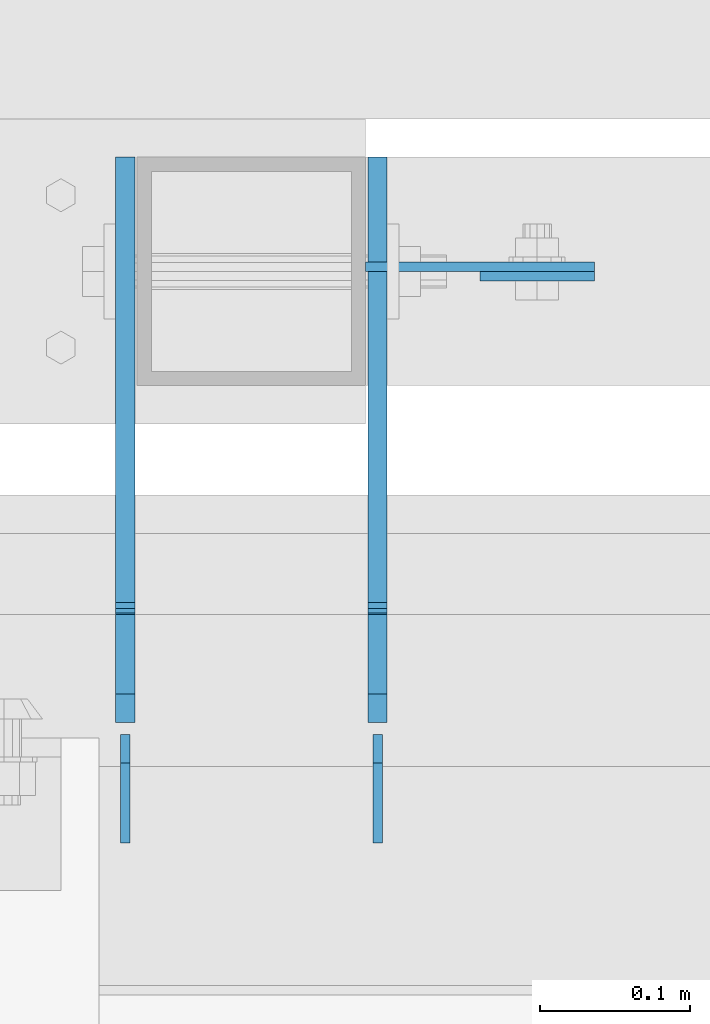
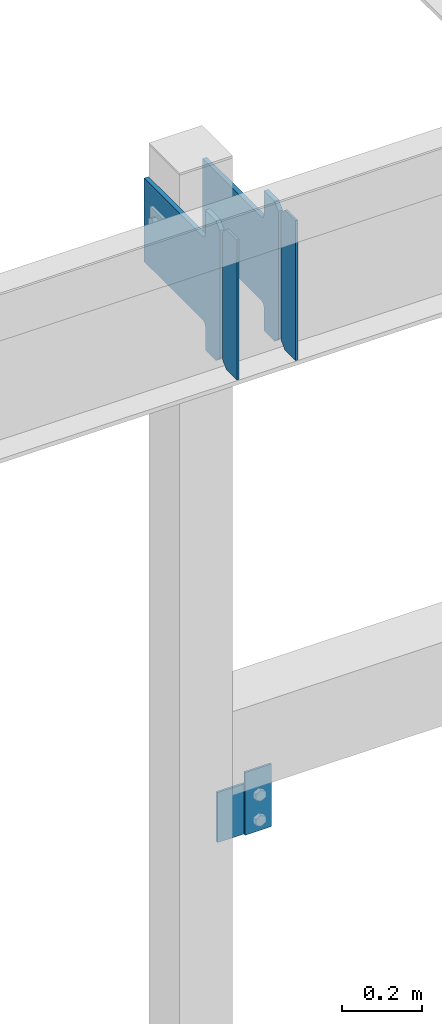
# One storey, part 3497 of 3843: 6 plates, 3 elements without a shape of their own.
"""IFC2X3 building model written with IfcOpenShell, lengths in millimetres."""

from ifc_helpers import new_model, si_unit, frame, origin_with_axes, place, context, subcontext, project, spatial, faceted_brep, material, type_object, element, aggregate, save


model = new_model("IFC2X3")

# Units and contexts
model_context = context("Model", 3, precision=1e-05, world=origin_with_axes())
body_context = subcontext(model_context, "Body", "Model", "MODEL_VIEW")
ifc_project = project(units=[si_unit("LENGTHUNIT", "METRE", prefix="MILLI"), si_unit("AREAUNIT", "SQUARE_METRE"), si_unit("VOLUMEUNIT", "CUBIC_METRE"), si_unit("MASSUNIT", "GRAM", prefix="KILO"), si_unit("TIMEUNIT", "SECOND"), si_unit("PLANEANGLEUNIT", "RADIAN"), si_unit("SOLIDANGLEUNIT", "STERADIAN"), si_unit("THERMODYNAMICTEMPERATUREUNIT", "DEGREE_CELSIUS"), si_unit("LUMINOUSINTENSITYUNIT", "LUMEN")], contexts=[model_context])

# Site, building, storey
site_placement = place(None, origin_with_axes())
site = spatial("IfcSite", under=ifc_project, at=site_placement, CompositionType="ELEMENT")
building_placement = place(site_placement, origin_with_axes())
building = spatial("IfcBuilding", under=site, at=building_placement, Name="Undefined", CompositionType="ELEMENT")
storey_placement = place(building_placement, origin_with_axes())
storey = spatial("IfcBuildingStorey", under=building, at=storey_placement, Name="Undefined", CompositionType="ELEMENT", Elevation=0.0)

# Assembly, plate
assembly_1_placement = place(storey_placement, origin_with_axes())
assembly_1 = element("IfcElementAssembly", 1, at=assembly_1_placement, inside=storey, Name="POST", AssemblyPlace="NOTDEFINED", PredefinedType="RIGID_FRAME")
ifc_material = material(Name="STEEL/A572-50")
plate_type_1 = type_object("IfcPlateType", PredefinedType="NOTDEFINED")
plate_1_placement = place(assembly_1_placement, frame((64033.4, 92522.675, 34455.1), z_axis=(0.0, 0.0, -1.0), x_axis=(1.0, 0.0, 0.0)))
plate_1 = element("IfcPlate", 2, at=plate_1_placement, type_object=plate_type_1, material=ifc_material, Name="PLATE", context=body_context, shape_type="Brep", body=[
    faceted_brep([(0.0, -3.17499999999927, 0.0), (1.52795109897852e-10, -3.17500000000291, 152.400000000009), (1.52795109897852e-10, 3.17500000000291, 152.400000000009), (0.0, 3.17499999999927, 0.0), (152.399993896484, -3.17500000000291, 152.399993896484), (152.399993896484, 3.17500000000291, 152.399993896484), (152.399998474109, -3.17500000000291, 0.0), (152.399998474109, 3.17500000000291, 0.0)], [[[0, 1, 2, 3]], [[1, 4, 5, 2]], [[4, 6, 7, 5]], [[6, 0, 3, 7]], [[5, 7, 3, 2]], [[6, 4, 1, 0]]]),
])
aggregate(assembly_1, [plate_1])

assembly_2_placement = place(storey_placement, origin_with_axes())
assembly_2 = element("IfcElementAssembly", 3, at=assembly_2_placement, inside=storey, Name="BEAM", AssemblyPlace="NOTDEFINED", PredefinedType="RIGID_FRAME")
plate_type_2 = type_object("IfcPlateType", PredefinedType="NOTDEFINED")
plate_2_placement = place(assembly_2_placement, frame((64185.7999938965, 92516.325, 34302.7000061036), z_axis=(-1.0, 0.0, 0.0), x_axis=(0.0, 0.0, 1.0)))
plate_2 = element("IfcPlate", 4, at=plate_2_placement, type_object=plate_type_2, material=ifc_material, Name="PLATE", context=body_context, shape_type="Brep", body=[
    faceted_brep([(0.0, -3.17499999999927, 0.0), (0.0, -3.17499999999927, 76.1999969482422), (0.0, 3.17499999999927, 76.1999969482422), (0.0, 3.17499999999927, 0.0), (190.5, -3.17500000000291, 76.1999969482422), (190.5, 3.17500000000291, 76.1999969482422), (190.5, -3.17500000000291, -3.63797880709171e-12), (190.5, 3.17500000000291, -3.63797880709171e-12)], [[[0, 1, 2, 3]], [[1, 4, 5, 2]], [[4, 6, 7, 5]], [[6, 0, 3, 7]], [[5, 7, 3, 2]], [[6, 4, 1, 0]]]),
])
aggregate(assembly_2, [plate_2])

# Assembly, plates
assembly_3_placement = place(storey_placement, origin_with_axes())
assembly_3 = element("IfcElementAssembly", 5, at=assembly_3_placement, inside=storey, Name="BEAM", AssemblyPlace="NOTDEFINED", PredefinedType="RIGID_FRAME")
plate_type_3 = type_object("IfcPlateType", PredefinedType="NOTDEFINED")
plate_3_placement = place(assembly_3_placement, frame((63873.0625, 92138.5, 35996.5625), z_axis=(0.0, 0.0, 1.0), x_axis=(0.0, 1.0, 0.0)))
plate_3 = element("IfcPlate", 6, at=plate_3_placement, type_object=plate_type_3, material=ifc_material, Name="PLATE", context=body_context, shape_type="Brep", body=[
    faceted_brep([(0.0, -3.17499999999927, 0.0), (0.0, -3.17500000000291, 425.449999999997), (0.0, 3.17500000000291, 425.449999999997), (0.0, 3.17499999999927, 0.0), (53.1812477111816, -3.17500000000291, 425.450012207031), (53.1812477111816, 3.17500000000291, 425.450012207031), (72.2312469482422, -3.17500000000291, 406.400012969971), (72.2312469482422, 3.17500000000291, 406.400012969971), (72.2312469482422, -3.17500000000291, 19.0499992370605), (72.2312469482422, 3.17500000000291, 19.0499992370605), (53.1812477111816, -3.17500000000291, 0.0), (53.1812477111816, 3.17500000000291, 0.0)], [[[0, 1, 2, 3]], [[1, 4, 5, 2]], [[4, 6, 7, 5]], [[6, 8, 9, 7]], [[8, 10, 11, 9]], [[10, 0, 3, 11]], [[5, 7, 9, 11, 3, 2]], [[10, 8, 6, 4, 1, 0]]]),
])
plate_4_placement = place(assembly_3_placement, frame((64041.3375, 92138.5, 35996.5625), z_axis=(0.0, 0.0, 1.0), x_axis=(0.0, 1.0, 0.0)))
plate_4 = element("IfcPlate", 7, at=plate_4_placement, type_object=plate_type_3, material=ifc_material, Name="PLATE", context=body_context, shape_type="Brep", body=[
    faceted_brep([(0.0, -3.17499999999927, 0.0), (0.0, -3.17500000000291, 425.449999999997), (0.0, 3.17500000000291, 425.449999999997), (0.0, 3.17499999999927, 0.0), (53.1812477111816, -3.17500000000291, 425.450012207031), (53.1812477111816, 3.17500000000291, 425.450012207031), (72.2312469482422, -3.17500000000291, 406.400012969971), (72.2312469482422, 3.17500000000291, 406.400012969971), (72.2312469482422, -3.17500000000291, 19.0499992370605), (72.2312469482422, 3.17500000000291, 19.0499992370605), (53.1812477111816, -3.17500000000291, 0.0), (53.1812477111816, 3.17500000000291, 0.0)], [[[0, 1, 2, 3]], [[1, 4, 5, 2]], [[4, 6, 7, 5]], [[6, 8, 9, 7]], [[8, 10, 11, 9]], [[10, 0, 3, 11]], [[5, 7, 9, 11, 3, 2]], [[10, 8, 6, 4, 1, 0]]]),
])
plate_type_4 = type_object("IfcPlateType", PredefinedType="NOTDEFINED")
plate_5_placement = place(assembly_3_placement, frame((63873.0625, 92218.66875, 35996.5625), z_axis=(0.0, 0.0, 1.0), x_axis=(0.0, 1.0, 0.0)))
plate_5 = element("IfcPlate", 8, at=plate_5_placement, type_object=plate_type_4, material=ifc_material, Name="PLATE", context=body_context, shape_type="Brep", body=[
    faceted_brep([(0.0, -6.34999999999854, 19.0499992370605), (0.0, -6.34999999999854, 406.400000762937), (0.0, 6.34999999999854, 406.400000762937), (0.0, 6.34999999999854, 19.0499992370605), (19.0499992370605, -6.34999999999854, 425.449999999997), (19.0499992370605, 6.34999999999854, 425.449999999997), (72.2312469482422, -6.35000000000582, 425.450012207031), (72.2312469482422, 6.35000000000582, 425.450012207031), (72.2312469482422, -6.35000000000582, 350.837505912779), (72.2312469482422, 6.35000000000582, 350.837505912779), (73.1979768708261, -6.35000000000582, 345.977426394733), (73.1979768708261, 6.35000000000582, 345.977426394733), (75.9509907713073, -6.35000000000582, 341.857249926579), (75.9509907713073, 6.35000000000582, 341.857249926579), (80.0711672394682, -6.35000000000582, 339.104236026105), (80.0711672394682, 6.35000000000582, 339.104236026105), (84.9312467575073, -6.35000000000582, 338.137506103514), (84.9312467575073, 6.35000000000582, 338.137506103514), (377.03125, -6.35000000000582, 338.137506103514), (377.03125, 6.35000000000582, 338.137506103514), (377.03125, -6.35000000000582, 84.1374969482422), (377.03125, 6.35000000000582, 84.1374969482422), (84.9312467575073, -6.35000000000582, 84.1374969482422), (84.9312467575073, 6.35000000000582, 84.1374969482422), (80.0711672394682, -6.35000000000582, 83.170767025651), (80.0711672394682, 6.35000000000582, 83.170767025651), (75.9509907713073, -6.35000000000582, 80.4177531251771), (75.9509907713073, 6.35000000000582, 80.4177531251771), (73.1979768708261, -6.35000000000582, 76.2975766570235), (73.1979768708261, 6.35000000000582, 76.2975766570235), (72.2312469482422, -6.35000000000582, 71.4374971389771), (72.2312469482422, 6.35000000000582, 71.4374971389771), (72.2312469482422, -6.35000000000582, 0.0), (72.2312469482422, 6.35000000000582, 0.0), (19.0499992370605, -6.34999999999854, 0.0), (19.0499992370605, 6.34999999999854, 0.0)], [[[0, 1, 2, 3]], [[1, 4, 5, 2]], [[4, 6, 7, 5]], [[6, 8, 9, 7]], [[8, 10, 11, 9]], [[10, 12, 13, 11]], [[12, 14, 15, 13]], [[14, 16, 17, 15]], [[16, 18, 19, 17]], [[18, 20, 21, 19]], [[20, 22, 23, 21]], [[22, 24, 25, 23]], [[24, 26, 27, 25]], [[26, 28, 29, 27]], [[28, 30, 31, 29]], [[30, 32, 33, 31]], [[32, 34, 35, 33]], [[34, 0, 3, 35]], [[5, 7, 9, 11, 13, 15, 17, 19, 21, 23, 25, 27, 29, 31, 33, 35, 3, 2]], [[34, 32, 30, 28, 26, 24, 22, 20, 18, 16, 14, 12, 10, 8, 6, 4, 1, 0]]]),
])
plate_6_placement = place(assembly_3_placement, frame((64041.3375, 92218.66875, 35996.5625), z_axis=(0.0, 0.0, 1.0), x_axis=(0.0, 1.0, 0.0)))
plate_6 = element("IfcPlate", 9, at=plate_6_placement, type_object=plate_type_4, material=ifc_material, Name="PLATE", context=body_context, shape_type="Brep", body=[
    faceted_brep([(0.0, -6.34999999999854, 19.0499992370605), (0.0, -6.34999999999854, 406.400000762937), (0.0, 6.34999999999854, 406.400000762937), (0.0, 6.34999999999854, 19.0499992370605), (19.0499992370605, -6.34999999999854, 425.449999999997), (19.0499992370605, 6.34999999999854, 425.449999999997), (72.2312469482422, -6.35000000000582, 425.450012207031), (72.2312469482422, 6.35000000000582, 425.450012207031), (72.2312469482422, -6.35000000000582, 350.837505912779), (72.2312469482422, 6.35000000000582, 350.837505912779), (73.1979768708261, -6.35000000000582, 345.977426394733), (73.1979768708261, 6.35000000000582, 345.977426394733), (75.9509907713073, -6.35000000000582, 341.857249926579), (75.9509907713073, 6.35000000000582, 341.857249926579), (80.0711672394682, -6.35000000000582, 339.104236026105), (80.0711672394682, 6.35000000000582, 339.104236026105), (84.9312467575073, -6.35000000000582, 338.137506103514), (84.9312467575073, 6.35000000000582, 338.137506103514), (377.03125, -6.35000000000582, 338.137506103514), (377.03125, 6.35000000000582, 338.137506103514), (377.03125, -6.35000000000582, 84.1374969482422), (377.03125, 6.35000000000582, 84.1374969482422), (84.9312467575073, -6.35000000000582, 84.1374969482422), (84.9312467575073, 6.35000000000582, 84.1374969482422), (80.0711672394682, -6.35000000000582, 83.170767025651), (80.0711672394682, 6.35000000000582, 83.170767025651), (75.9509907713073, -6.35000000000582, 80.4177531251771), (75.9509907713073, 6.35000000000582, 80.4177531251771), (73.1979768708261, -6.35000000000582, 76.2975766570235), (73.1979768708261, 6.35000000000582, 76.2975766570235), (72.2312469482422, -6.35000000000582, 71.4374971389771), (72.2312469482422, 6.35000000000582, 71.4374971389771), (72.2312469482422, -6.35000000000582, 0.0), (72.2312469482422, 6.35000000000582, 0.0), (19.0499992370605, -6.34999999999854, 0.0), (19.0499992370605, 6.34999999999854, 0.0)], [[[0, 1, 2, 3]], [[1, 4, 5, 2]], [[4, 6, 7, 5]], [[6, 8, 9, 7]], [[8, 10, 11, 9]], [[10, 12, 13, 11]], [[12, 14, 15, 13]], [[14, 16, 17, 15]], [[16, 18, 19, 17]], [[18, 20, 21, 19]], [[20, 22, 23, 21]], [[22, 24, 25, 23]], [[24, 26, 27, 25]], [[26, 28, 29, 27]], [[28, 30, 31, 29]], [[30, 32, 33, 31]], [[32, 34, 35, 33]], [[34, 0, 3, 35]], [[5, 7, 9, 11, 13, 15, 17, 19, 21, 23, 25, 27, 29, 31, 33, 35, 3, 2]], [[34, 32, 30, 28, 26, 24, 22, 20, 18, 16, 14, 12, 10, 8, 6, 4, 1, 0]]]),
])
aggregate(assembly_3, [plate_3, plate_4, plate_5, plate_6])

save(model, "model.ifc")
